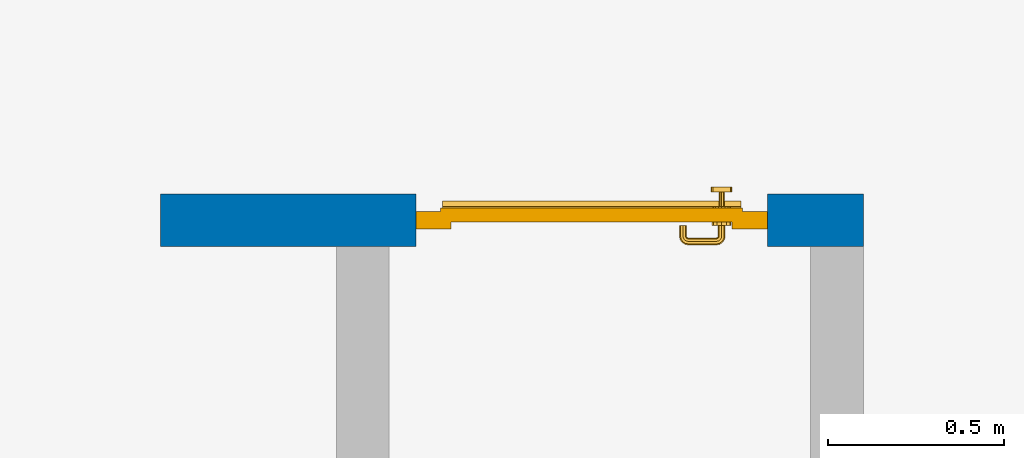
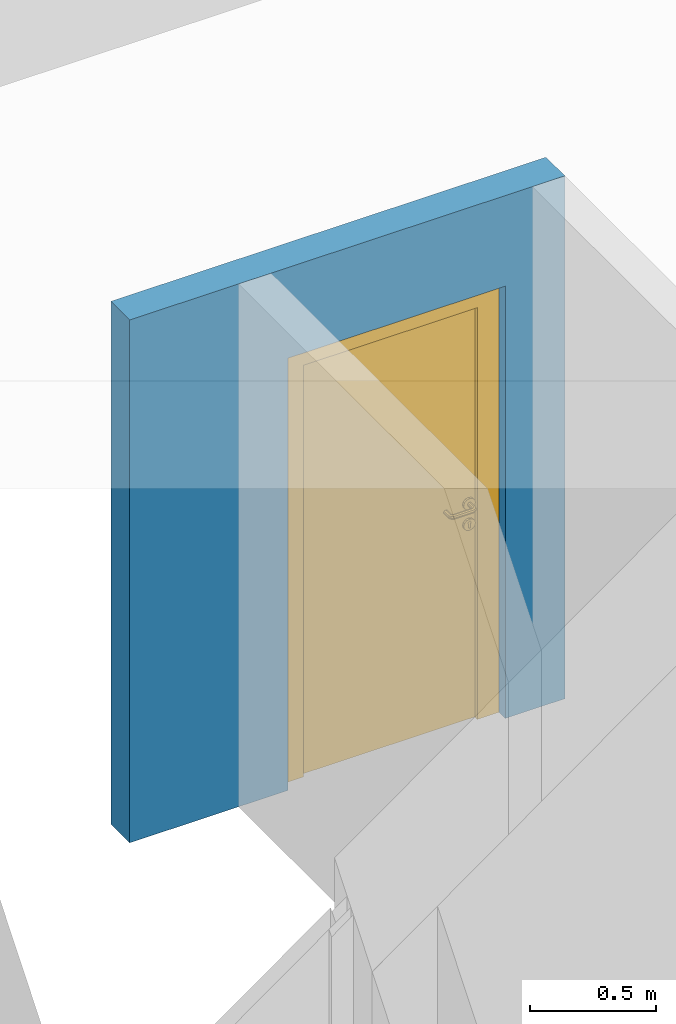
# One storey, part 20 of 48: 1 door, 1 wall, 1 opening.
"""IFC4 building model written with IfcOpenShell, lengths in metres."""

from ifc_helpers import new_model, entity, si_unit, converted_unit, derived_unit, direction, frame, origin_with_axes, place, context, subcontext, project, spatial, polygons, source, transform, mapped, material, type_object, element, fill, save


model = new_model("IFC4")

# Units and contexts
model_context = context("Model", 3, precision=1e-05, world=origin_with_axes(), true_north=direction((0.0, 1.0)))
body_context = subcontext(model_context, "Body", "Model", "MODEL_VIEW")
ifc_project = project(units=[si_unit("LENGTHUNIT", "METRE"), si_unit("AREAUNIT", "SQUARE_METRE"), si_unit("VOLUMEUNIT", "CUBIC_METRE"), converted_unit("PLANEANGLEUNIT", "DEGREE", entity("IfcPlaneAngleMeasure", 0.0174532925199), si_unit("PLANEANGLEUNIT", "RADIAN"), dimensions=[0, 0, 0, 0, 0, 0, 0]), converted_unit("TIMEUNIT", "Year", entity("IfcTimeMeasure", 31556926.0), si_unit("TIMEUNIT", "SECOND"), dimensions=[0, 0, 1, 0, 0, 0, 0]), si_unit("MASSUNIT", "GRAM", prefix="KILO"), si_unit("THERMODYNAMICTEMPERATUREUNIT", "DEGREE_CELSIUS"), si_unit("LUMINOUSINTENSITYUNIT", "LUMEN"), si_unit("ENERGYUNIT", "JOULE", prefix="MEGA"), derived_unit("THERMALCONDUCTANCEUNIT", [(si_unit("POWERUNIT", "WATT"), 1), (si_unit("LENGTHUNIT", "METRE"), -1), (si_unit("THERMODYNAMICTEMPERATUREUNIT", "KELVIN"), -1)]), derived_unit("SPECIFICHEATCAPACITYUNIT", [(si_unit("ENERGYUNIT", "JOULE"), 1), (si_unit("MASSUNIT", "GRAM", prefix="KILO"), -1), (si_unit("THERMODYNAMICTEMPERATUREUNIT", "KELVIN"), -1)]), derived_unit("MASSDENSITYUNIT", [(si_unit("MASSUNIT", "GRAM", prefix="KILO"), 1), (si_unit("VOLUMEUNIT", "CUBIC_METRE"), -1)])], contexts=[model_context])

# Site, building, storey
site_placement = place(None, origin_with_axes())
site = spatial("IfcSite", under=ifc_project, at=site_placement, CompositionType="ELEMENT")
building_placement = place(site_placement, origin_with_axes())
building = spatial("IfcBuilding", under=site, at=building_placement, CompositionType="ELEMENT")
storey_placement = place(building_placement, frame((0.0, 0.0, 3.4), z_axis=(0.0, 0.0, 1.0), x_axis=(1.0, 0.0, 0.0)))
storey = spatial("IfcBuildingStorey", under=building, at=storey_placement, Name="1. Geschoss", CompositionType="ELEMENT", Elevation=3.4)

# Wall, opening, door
ifc_material = material()
wall_type = type_object("IfcWallType", Name="150", PredefinedType="NOTDEFINED")
wall_placement = place(storey_placement, frame((4.6878006196, 3.97118776896, 0.0), z_axis=(0.0, 0.0, 1.0), x_axis=(-1.0, 0.0, 0.0)))
wall = element("IfcWall", 1, at=wall_placement, inside=storey, type_object=wall_type, material=ifc_material, Name="Wand-002", PredefinedType="NOTDEFINED", context=body_context, shape_type="Tessellation", body=[
    polygons([(0.12346205006, 0.05, 0.0), (0.12346205006, 0.05, 2.1), (0.12346205006, 0.0, 2.1), (0.12346205006, 0.0, 0.0), (0.12346205006, 0.15, 0.0), (0.12346205006, 0.15, 2.1), (1.12346205006, 0.05, 2.1), (1.12346205006, 0.0, 2.1), (-0.15, 0.0, 0.0), (1.12346205006, 0.0, 0.0), (1.85, 0.0, 0.0), (1.85, 0.0, 2.54), (-0.15, 0.0, 2.54), (-0.15, 0.15, 0.0), (-0.15, 0.15, 2.54), (1.85, 0.15, 2.54), (1.85, 0.15, 0.0), (1.12346205006, 0.15, 0.0), (1.12346205006, 0.15, 2.1), (1.12346205006, 0.05, 0.0)], [[[1, 2, 3, 4]], [[2, 1, 5, 6]], [[2, 7, 8, 3]], [[9, 4, 3, 8, 10, 11, 12, 13]], [[5, 1, 4, 9, 14]], [[6, 5, 14, 15, 16, 17, 18, 19]], [[7, 2, 6, 19]], [[7, 20, 10, 8]], [[20, 18, 17, 11, 10]], [[12, 11, 17, 16]], [[13, 12, 16, 15]], [[15, 14, 9, 13]], [[20, 7, 19, 18]]], closed=True),
])
opening_placement = place(wall_placement, frame((0.62346205006, 0.0, 0.0), z_axis=(0.0, 0.0, 1.0), x_axis=(1.0, 0.0, 0.0)))
opening = element("IfcOpeningElement", 2, at=opening_placement, cuts=wall, context=body_context, identifier="Reference", shape_type="Tessellation", body=[
    polygons([(0.5, 0.05, 0.0), (0.5, 0.05, 2.1), (0.5, -0.001, 2.1), (0.5, -0.001, 0.0), (0.5, 0.151, 0.0), (0.5, 0.151, 2.1), (-0.5, 0.05, 2.1), (-0.5, -0.001, 2.1), (-0.5, 0.151, 2.1), (-0.5, -0.001, 0.0), (-0.5, 0.05, 0.0), (-0.5, 0.151, 0.0)], [[[1, 2, 3, 4]], [[2, 1, 5, 6]], [[7, 8, 3, 2, 6, 9]], [[8, 10, 4, 3]], [[1, 4, 10, 11, 12, 5]], [[6, 5, 12, 9]], [[7, 11, 10, 8]], [[11, 7, 9, 12]]], closed=True),
])
door_type = type_object("IfcDoorType", Name="Eingang 01 1-Fl 26", OperationType="SINGLE_SWING_LEFT", PredefinedType="DOOR")
shared_shape = source(origin_with_axes(), body_context, "Body", "Tessellation", [
    polygons([(-0.5, -0.05, 0.0), (-0.5, -0.05, 2.1), (-0.5, -0.03, 2.1), (-0.5, -0.03, 0.0), (-0.4, -0.05, 0.0), (-0.4, -0.05, 2.0), (-0.1301, -0.05, 2.0), (-0.0001, -0.05, 2.0), (0.4, -0.05, 2.0), (0.4, -0.05, 0.0), (0.5, -0.05, 0.0), (0.5, -0.05, 2.1), (0.5, -0.03, 2.1), (0.5, -0.03, 0.0), (0.4, -0.03, 0.0), (0.4, -0.03, 2.0), (-0.0001, -0.03, 2.0), (-0.1301, -0.03, 2.0), (-0.4, -0.03, 2.0), (-0.4, -0.03, 0.0)], [[[1, 2, 3, 4]], [[1, 5, 6, 7, 8, 9, 10, 11, 12, 2]], [[2, 12, 13, 3]], [[4, 3, 13, 14, 15, 16, 17, 18, 19, 20]], [[5, 1, 4, 20]], [[6, 5, 20, 19]], [[7, 6, 19, 18]], [[8, 7, 18, 17]], [[9, 8, 17, 16]], [[10, 9, 16, 15]], [[11, 10, 15, 14]], [[12, 11, 14, 13]]], closed=True),
    polygons([(-0.5, -0.03, 0.0), (-0.5, -0.03, 2.1), (-0.5, 0.0, 2.1), (-0.5, 0.0, 0.0), (-0.43, -0.03, 0.0), (-0.43, -0.03, 2.03), (-0.1001, -0.03, 2.03), (-0.0301, -0.03, 2.03), (0.43, -0.03, 2.03), (0.43, -0.03, 0.0), (0.5, -0.03, 0.0), (0.5, -0.03, 2.1), (0.5, 0.0, 2.1), (0.5, 0.0, 0.0), (0.43, 0.0, 0.0), (0.43, 0.0, 2.03), (-0.0301, 0.0, 2.03), (-0.1001, 0.0, 2.03), (-0.43, 0.0, 2.03), (-0.43, 0.0, 0.0)], [[[1, 2, 3, 4]], [[1, 5, 6, 7, 8, 9, 10, 11, 12, 2]], [[2, 12, 13, 3]], [[4, 3, 13, 14, 15, 16, 17, 18, 19, 20]], [[5, 1, 4, 20]], [[6, 5, 20, 19]], [[7, 6, 19, 18]], [[8, 7, 18, 17]], [[9, 8, 17, 16]], [[10, 9, 16, 15]], [[11, 10, 15, 14]], [[12, 11, 14, 13]]], closed=True),
    polygons([(-0.43, 0.01, 0.0), (-0.43, 0.01, 2.03), (0.43, 0.01, 2.03), (0.43, 0.01, 0.0), (-0.43, -0.03, 0.0), (-0.43, -0.03, 2.03), (0.43, -0.03, 2.03), (0.43, -0.03, 0.0)], [[[1, 2, 3, 4]], [[1, 5, 6, 2]], [[2, 6, 7, 3]], [[3, 7, 8, 4]], [[4, 8, 5, 1]], [[8, 7, 6, 5]]], closed=True),
    polygons([(-0.425, 0.03, 0.0), (-0.425, 0.03, 0.05), (0.425, 0.03, 0.05), (0.425, 0.03, 0.0), (-0.425, 0.01, 0.0), (-0.425, 0.01, 0.07), (-0.425, 0.015, 0.07), (0.425, 0.015, 0.07), (0.425, 0.01, 0.07), (0.425, 0.01, 0.0)], [[[1, 2, 3, 4]], [[1, 5, 6, 7, 2]], [[2, 7, 8, 3]], [[4, 3, 8, 9, 10]], [[5, 1, 4, 10]], [[6, 5, 10, 9]], [[7, 6, 9, 8]]], closed=True),
    polygons([(0.3835, -0.04, 1.0733826859), (0.3835, -0.0399, 1.0733826859), (0.37, -0.0399, 1.077), (0.37, -0.04, 1.077), (0.393382685902, -0.04, 1.0635), (0.393382685902, -0.0399, 1.0635), (0.3835, -0.0301, 1.0733826859), (0.37, -0.0301, 1.077), (0.3565, -0.0399, 1.0733826859), (0.3565, -0.04, 1.0733826859), (0.346617314098, -0.04, 1.0635), (0.343, -0.04, 1.05), (0.346617314098, -0.04, 1.0365), (0.3565, -0.04, 1.0266173141), (0.37, -0.04, 1.023), (0.3835, -0.04, 1.0266173141), (0.393382685902, -0.04, 1.0365), (0.397, -0.04, 1.05), (0.397, -0.0399, 1.05), (0.393382685902, -0.0301, 1.0635), (0.3835, -0.03, 1.0733826859), (0.37, -0.03, 1.077), (0.3565, -0.0301, 1.0733826859), (0.346617314098, -0.0399, 1.0635), (0.343, -0.0399, 1.05), (0.346617314098, -0.0399, 1.0365), (0.3565, -0.0399, 1.0266173141), (0.37, -0.0399, 1.023), (0.3835, -0.0399, 1.0266173141), (0.393382685902, -0.0399, 1.0365), (0.397, -0.0301, 1.05), (0.393382685902, -0.03, 1.0635), (0.397, -0.03, 1.05), (0.393382685902, -0.03, 1.0365), (0.3835, -0.03, 1.0266173141), (0.37, -0.03, 1.023), (0.3565, -0.03, 1.0266173141), (0.346617314098, -0.03, 1.0365), (0.343, -0.03, 1.05), (0.346617314098, -0.03, 1.0635), (0.3565, -0.03, 1.0733826859), (0.346617314098, -0.0301, 1.0635), (0.343, -0.0301, 1.05), (0.346617314098, -0.0301, 1.0365), (0.3565, -0.0301, 1.0266173141), (0.37, -0.0301, 1.023), (0.3835, -0.0301, 1.0266173141), (0.393382685902, -0.0301, 1.0365)], [[[1, 2, 3, 4]], [[5, 6, 2, 1]], [[2, 7, 8, 3]], [[4, 3, 9, 10]], [[4, 10, 11, 12, 13, 14, 15, 16, 17, 18, 5, 1]], [[18, 19, 6, 5]], [[6, 20, 7, 2]], [[7, 21, 22, 8]], [[3, 8, 23, 9]], [[10, 9, 24, 11]], [[11, 24, 25, 12]], [[12, 25, 26, 13]], [[13, 26, 27, 14]], [[14, 27, 28, 15]], [[15, 28, 29, 16]], [[16, 29, 30, 17]], [[17, 30, 19, 18]], [[19, 31, 20, 6]], [[20, 32, 21, 7]], [[22, 21, 32, 33, 34, 35, 36, 37, 38, 39, 40, 41]], [[8, 22, 41, 23]], [[9, 23, 42, 24]], [[24, 42, 43, 25]], [[25, 43, 44, 26]], [[26, 44, 45, 27]], [[27, 45, 46, 28]], [[28, 46, 47, 29]], [[29, 47, 48, 30]], [[30, 48, 31, 19]], [[31, 33, 32, 20]], [[48, 34, 33, 31]], [[47, 35, 34, 48]], [[46, 36, 35, 47]], [[45, 37, 36, 46]], [[44, 38, 37, 45]], [[43, 39, 38, 44]], [[42, 40, 39, 43]], [[23, 41, 40, 42]]], closed=True),
    polygons([(0.362532169224, -0.04, 0.959692280177), (0.363279754556, -0.04, 0.961639806549), (0.35655, -0.04, 0.973296083362), (0.346703916638, -0.04, 0.96345), (0.365, -0.04, 0.952886751346), (0.365, -0.04, 0.9544), (0.362532169224, -0.039, 0.959692280177), (0.363279754556, -0.039, 0.961639806549), (0.364624817685, -0.039, 0.965143815798), (0.364624817685, -0.04, 0.965143815798), (0.37, -0.04, 0.967425445323), (0.37, -0.04, 0.9769), (0.346617314098, -0.04, 0.9635), (0.3565, -0.04, 0.973382685902), (0.365, -0.04, 0.95), (0.3431, -0.04, 0.95), (0.365, -0.04, 0.947113248654), (0.365, -0.04, 0.941339745962), (0.365, -0.04, 0.9375), (0.365, -0.039, 0.9375), (0.365, -0.039, 0.941339745962), (0.365, -0.039, 0.947113248654), (0.365, -0.039, 0.95), (0.365, -0.039, 0.952886751346), (0.365, -0.039, 0.9544), (0.347569942042, -0.039, 0.96295), (0.35705, -0.039, 0.972430057958), (0.37, -0.039, 0.9759), (0.37, -0.039, 0.967425445323), (0.375375182315, -0.04, 0.965143815798), (0.376720245444, -0.04, 0.961639806549), (0.38345, -0.04, 0.973296083362), (0.37, -0.04, 0.977), (0.343, -0.04, 0.95), (0.346617314098, -0.0399, 0.9635), (0.3565, -0.0399, 0.973382685902), (0.346703916638, -0.04, 0.93655), (0.35655, -0.04, 0.926703916638), (0.37, -0.04, 0.9231), (0.37, -0.04, 0.9325), (0.366464466094, -0.04, 0.933964466094), (0.366464466094, -0.039, 0.933964466094), (0.37, -0.039, 0.9241), (0.35705, -0.039, 0.927569942042), (0.37, -0.039, 0.9325), (0.347569942042, -0.039, 0.93705), (0.3441, -0.039, 0.95), (0.347483339502, -0.039, 0.963), (0.357, -0.039, 0.972516660498), (0.37, -0.039, 0.976), (0.375375182315, -0.039, 0.965143815798), (0.38295, -0.039, 0.972430057958), (0.376720245444, -0.039, 0.961639806549), (0.377467830776, -0.039, 0.959692280177), (0.377467830776, -0.04, 0.959692280177), (0.375, -0.04, 0.9544), (0.375, -0.04, 0.952886751346), (0.393296083362, -0.04, 0.96345), (0.3835, -0.04, 0.973382685902), (0.37, -0.0399, 0.977), (0.346617314098, -0.04, 0.9365), (0.343, -0.0399, 0.95), (0.346617314098, -0.0301, 0.9635), (0.3565, -0.0301, 0.973382685902), (0.3565, -0.04, 0.926617314098), (0.37, -0.04, 0.923), (0.38345, -0.04, 0.926703916638), (0.375, -0.04, 0.941339745962), (0.375, -0.04, 0.9375), (0.373535533906, -0.04, 0.933964466094), (0.37, -0.039, 0.924), (0.357, -0.039, 0.927483339502), (0.38295, -0.039, 0.927569942042), (0.373535533906, -0.039, 0.933964466094), (0.375, -0.039, 0.9375), (0.375, -0.039, 0.941339745962), (0.347483339502, -0.039, 0.937), (0.344, -0.039, 0.95), (0.347483339502, -0.0389, 0.963), (0.357, -0.0389, 0.972516660498), (0.37, -0.0389, 0.976), (0.383, -0.039, 0.972516660498), (0.392430057958, -0.039, 0.96295), (0.375, -0.039, 0.952886751346), (0.375, -0.039, 0.9544), (0.375, -0.039, 0.95), (0.375, -0.039, 0.947113248654), (0.375, -0.04, 0.947113248654), (0.375, -0.04, 0.95), (0.3969, -0.04, 0.95), (0.393382685902, -0.04, 0.9635), (0.3835, -0.0399, 0.973382685902), (0.37, -0.0301, 0.977), (0.346617314098, -0.0399, 0.9365), (0.343, -0.0301, 0.95), (0.346617314098, -0.03, 0.9635), (0.3565, -0.03, 0.973382685902), (0.3565, -0.0399, 0.926617314098), (0.3835, -0.04, 0.926617314098), (0.37, -0.0399, 0.923), (0.393296083362, -0.04, 0.93655), (0.383, -0.039, 0.927483339502), (0.37, -0.0389, 0.924), (0.357, -0.0389, 0.927483339502), (0.392430057958, -0.039, 0.93705), (0.347483339502, -0.0389, 0.937), (0.344, -0.0389, 0.95), (0.347483339502, -0.0301, 0.963), (0.357, -0.0301, 0.972516660498), (0.37, -0.0301, 0.976), (0.383, -0.0389, 0.972516660498), (0.392516660498, -0.039, 0.963), (0.3959, -0.039, 0.95), (0.397, -0.04, 0.95), (0.393382685902, -0.0399, 0.9635), (0.3835, -0.0301, 0.973382685902), (0.37, -0.03, 0.977), (0.346617314098, -0.0301, 0.9365), (0.343, -0.03, 0.95), (0.346703916638, -0.03, 0.96345), (0.35655, -0.03, 0.973296083362), (0.3565, -0.0301, 0.926617314098), (0.393382685902, -0.04, 0.9365), (0.3835, -0.0399, 0.926617314098), (0.37, -0.0301, 0.923), (0.392516660498, -0.039, 0.937), (0.383, -0.0389, 0.927483339502), (0.37, -0.0301, 0.924), (0.357, -0.0301, 0.927483339502), (0.347483339502, -0.0301, 0.937), (0.344, -0.0301, 0.95), (0.347483339502, -0.03, 0.963), (0.357, -0.03, 0.972516660498), (0.37, -0.03, 0.976), (0.383, -0.0301, 0.972516660498), (0.392516660498, -0.0389, 0.963), (0.396, -0.039, 0.95), (0.397, -0.0399, 0.95), (0.393382685902, -0.0301, 0.9635), (0.3835, -0.03, 0.973382685902), (0.37, -0.03, 0.9769), (0.346617314098, -0.03, 0.9365), (0.3431, -0.03, 0.95), (0.347396736961, -0.03, 0.96305), (0.35695, -0.03, 0.972603263039), (0.3565, -0.03, 0.926617314098), (0.393382685902, -0.0399, 0.9365), (0.3835, -0.0301, 0.926617314098), (0.37, -0.03, 0.923), (0.392516660498, -0.0389, 0.937), (0.383, -0.0301, 0.927483339502), (0.37, -0.03, 0.924), (0.357, -0.03, 0.927483339502), (0.347483339502, -0.03, 0.937), (0.344, -0.03, 0.95), (0.37, -0.03, 0.9761), (0.383, -0.03, 0.972516660498), (0.392516660498, -0.0301, 0.963), (0.396, -0.0389, 0.95), (0.397, -0.0301, 0.95), (0.393382685902, -0.03, 0.9635), (0.38345, -0.03, 0.973296083362), (0.346703916638, -0.03, 0.93655), (0.3439, -0.03, 0.95), (0.35655, -0.03, 0.926703916638), (0.393382685902, -0.0301, 0.9365), (0.3835, -0.03, 0.926617314098), (0.37, -0.03, 0.9231), (0.392516660498, -0.0301, 0.937), (0.383, -0.03, 0.927483339502), (0.37, -0.03, 0.9239), (0.35695, -0.03, 0.927396736961), (0.347396736961, -0.03, 0.93695), (0.38305, -0.03, 0.972603263039), (0.392516660498, -0.03, 0.963), (0.396, -0.0301, 0.95), (0.397, -0.03, 0.95), (0.393296083362, -0.03, 0.96345), (0.393382685902, -0.03, 0.9365), (0.38345, -0.03, 0.926703916638), (0.392516660498, -0.03, 0.937), (0.38305, -0.03, 0.927396736961), (0.392603263039, -0.03, 0.96305), (0.396, -0.03, 0.95), (0.3969, -0.03, 0.95), (0.393296083362, -0.03, 0.93655), (0.392603263039, -0.03, 0.93695), (0.3961, -0.03, 0.95)], [[[1, 2, 3, 4, 5, 6]], [[1, 7, 8, 9, 10, 2]], [[10, 11, 12, 3, 2]], [[13, 4, 3, 14]], [[15, 5, 4, 16]], [[6, 5, 15, 17, 18, 19, 20, 21, 22, 23, 24, 25]], [[6, 25, 7, 1]], [[7, 25, 24, 26, 27, 8]], [[9, 8, 27, 28, 29]], [[10, 9, 29, 11]], [[30, 31, 32, 12, 11]], [[14, 3, 12, 33]], [[34, 16, 4, 13]], [[35, 13, 14, 36]], [[17, 15, 16, 37]], [[18, 17, 37, 38]], [[38, 39, 40, 41, 19, 18]], [[19, 41, 42, 20]], [[43, 44, 21, 20, 42, 45]], [[22, 21, 44, 46]], [[23, 22, 46, 47]], [[24, 23, 47, 26]], [[26, 48, 49, 27]], [[27, 49, 50, 28]], [[51, 29, 28, 52, 53]], [[11, 29, 51, 30]], [[30, 51, 53, 54, 55, 31]], [[55, 56, 57, 58, 32, 31]], [[33, 12, 32, 59]], [[36, 14, 33, 60]], [[61, 37, 16, 34]], [[62, 34, 13, 35]], [[63, 35, 36, 64]], [[65, 38, 37, 61]], [[66, 39, 38, 65]], [[39, 67, 68, 69, 70, 40]], [[41, 40, 45, 42]], [[43, 71, 72, 44]], [[73, 43, 45, 74, 75, 76]], [[44, 72, 77, 46]], [[46, 77, 78, 47]], [[47, 78, 48, 26]], [[48, 79, 80, 49]], [[49, 80, 81, 50]], [[28, 50, 82, 52]], [[54, 53, 52, 83, 84, 85]], [[55, 54, 85, 56]], [[85, 84, 86, 87, 76, 75, 69, 68, 88, 89, 57, 56]], [[57, 89, 90, 58]], [[59, 32, 58, 91]], [[60, 33, 59, 92]], [[64, 36, 60, 93]], [[94, 61, 34, 62]], [[95, 62, 35, 63]], [[96, 63, 64, 97]], [[98, 65, 61, 94]], [[99, 67, 39, 66]], [[100, 66, 65, 98]], [[88, 68, 67, 101]], [[70, 69, 75, 74]], [[40, 70, 74, 45]], [[73, 102, 71, 43]], [[71, 103, 104, 72]], [[76, 87, 105, 73]], [[72, 104, 106, 77]], [[77, 106, 107, 78]], [[78, 107, 79, 48]], [[79, 108, 109, 80]], [[80, 109, 110, 81]], [[50, 81, 111, 82]], [[52, 82, 112, 83]], [[86, 84, 83, 113]], [[87, 86, 113, 105]], [[89, 88, 101, 90]], [[91, 58, 90, 114]], [[92, 59, 91, 115]], [[93, 60, 92, 116]], [[97, 64, 93, 117]], [[118, 94, 62, 95]], [[119, 95, 63, 96]], [[120, 96, 97, 121]], [[122, 98, 94, 118]], [[123, 101, 67, 99]], [[124, 99, 66, 100]], [[125, 100, 98, 122]], [[105, 126, 102, 73]], [[102, 127, 103, 71]], [[103, 128, 129, 104]], [[104, 129, 130, 106]], [[106, 130, 131, 107]], [[107, 131, 108, 79]], [[108, 132, 133, 109]], [[109, 133, 134, 110]], [[81, 110, 135, 111]], [[82, 111, 136, 112]], [[83, 112, 137, 113]], [[113, 137, 126, 105]], [[114, 90, 101, 123]], [[115, 91, 114, 138]], [[116, 92, 115, 139]], [[117, 93, 116, 140]], [[121, 97, 117, 141]], [[142, 118, 95, 119]], [[143, 119, 96, 120]], [[144, 120, 121, 145]], [[146, 122, 118, 142]], [[147, 123, 99, 124]], [[148, 124, 100, 125]], [[149, 125, 122, 146]], [[126, 150, 127, 102]], [[127, 151, 128, 103]], [[128, 152, 153, 129]], [[129, 153, 154, 130]], [[130, 154, 155, 131]], [[131, 155, 132, 108]], [[132, 144, 145, 133]], [[133, 145, 156, 134]], [[110, 134, 157, 135]], [[111, 135, 158, 136]], [[112, 136, 159, 137]], [[137, 159, 150, 126]], [[138, 114, 123, 147]], [[139, 115, 138, 160]], [[140, 116, 139, 161]], [[141, 117, 140, 162]], [[145, 121, 141, 156]], [[163, 142, 119, 143]], [[164, 143, 120, 144]], [[165, 146, 142, 163]], [[166, 147, 124, 148]], [[167, 148, 125, 149]], [[168, 149, 146, 165]], [[150, 169, 151, 127]], [[151, 170, 152, 128]], [[152, 171, 172, 153]], [[153, 172, 173, 154]], [[154, 173, 164, 155]], [[155, 164, 144, 132]], [[134, 156, 174, 157]], [[135, 157, 175, 158]], [[136, 158, 176, 159]], [[159, 176, 169, 150]], [[160, 138, 147, 166]], [[161, 139, 160, 177]], [[162, 140, 161, 178]], [[156, 141, 162, 174]], [[173, 163, 143, 164]], [[172, 165, 163, 173]], [[179, 166, 148, 167]], [[180, 167, 149, 168]], [[171, 168, 165, 172]], [[169, 181, 170, 151]], [[170, 182, 171, 152]], [[157, 174, 183, 175]], [[158, 175, 184, 176]], [[176, 184, 181, 169]], [[177, 160, 166, 179]], [[178, 161, 177, 185]], [[174, 162, 178, 183]], [[186, 179, 167, 180]], [[182, 180, 168, 171]], [[181, 187, 182, 170]], [[175, 183, 188, 184]], [[184, 188, 187, 181]], [[185, 177, 179, 186]], [[183, 178, 185, 188]], [[187, 186, 180, 182]], [[188, 185, 186, 187]]], closed=True),
    polygons([(0.38, -0.04, 1.05), (0.38, -0.0709849140336, 1.05), (0.377071067812, -0.070696439392, 1.04292893219), (0.377071067812, -0.04, 1.04292893219), (0.377071067812, -0.04, 1.05707106781), (0.377071067812, -0.070696439392, 1.05707106781), (0.378277987014, -0.0796420579258, 1.05), (0.375518993221, -0.0784992452783, 1.04292893219), (0.37, -0.07, 1.04), (0.37, -0.04, 1.04), (0.37, -0.04, 1.06), (0.37, -0.07, 1.06), (0.375518993221, -0.0784992452783, 1.05707106781), (0.372816199938, -0.0878161999379, 1.05), (0.370704557509, -0.0857045575088, 1.04292893219), (0.368858192988, -0.0757402514855, 1.04), (0.362928932188, -0.069303560608, 1.04292893219), (0.362928932188, -0.04, 1.04292893219), (0.362928932188, -0.04, 1.05707106781), (0.362928932188, -0.069303560608, 1.05707106781), (0.368858192988, -0.0757402514855, 1.06), (0.370704557509, -0.0857045575088, 1.05707106781), (0.364642057926, -0.0932779870137, 1.05), (0.363499245278, -0.0905189932208, 1.04292893219), (0.365606601718, -0.0806066017178, 1.04), (0.362197392755, -0.0729812576926, 1.04292893219), (0.36, -0.0690150859664, 1.05), (0.36, -0.04, 1.05), (0.362197392755, -0.0729812576926, 1.05707106781), (0.365606601718, -0.0806066017178, 1.06), (0.363499245278, -0.0905189932208, 1.05707106781), (0.355984914034, -0.095, 1.05), (0.355696439392, -0.0920710678119, 1.04292893219), (0.360740251485, -0.0838581929877, 1.04), (0.360508645927, -0.0755086459268, 1.04292893219), (0.359438398962, -0.0718384450452, 1.05), (0.360508645927, -0.0755086459268, 1.05707106781), (0.360740251485, -0.0838581929877, 1.06), (0.355696439392, -0.0920710678119, 1.05707106781), (0.274015085966, -0.095, 1.05), (0.274303560608, -0.0920710678119, 1.04292893219), (0.355, -0.085, 1.04), (0.357981257693, -0.0771973927545, 1.04292893219), (0.358397003498, -0.0733970034977, 1.05), (0.357981257693, -0.0771973927545, 1.05707106781), (0.355, -0.085, 1.06), (0.274303560608, -0.0920710678119, 1.05707106781), (0.265357942074, -0.0932779870137, 1.05), (0.266500754722, -0.0905189932208, 1.04292893219), (0.275, -0.085, 1.04), (0.354303560608, -0.0779289321881, 1.04292893219), (0.356838445045, -0.0744383989617, 1.05), (0.354303560608, -0.0779289321881, 1.05707106781), (0.275, -0.085, 1.06), (0.266500754722, -0.0905189932208, 1.05707106781), (0.257183800062, -0.0878161999379, 1.05), (0.259295442491, -0.0857045575088, 1.04292893219), (0.269259748515, -0.0838581929877, 1.04), (0.275696439392, -0.0779289321881, 1.04292893219), (0.354015085966, -0.075, 1.05), (0.275696439392, -0.0779289321881, 1.05707106781), (0.269259748515, -0.0838581929877, 1.06), (0.259295442491, -0.0857045575088, 1.05707106781), (0.251722012986, -0.0796420579258, 1.05), (0.254481006779, -0.0784992452783, 1.04292893219), (0.264393398282, -0.0806066017178, 1.04), (0.272018742307, -0.0771973927545, 1.04292893219), (0.275984914034, -0.075, 1.05), (0.272018742307, -0.0771973927545, 1.05707106781), (0.264393398282, -0.0806066017178, 1.06), (0.254481006779, -0.0784992452783, 1.05707106781), (0.25, -0.0709849140336, 1.05), (0.252928932188, -0.070696439392, 1.04292893219), (0.261141807012, -0.0757402514855, 1.04), (0.269491354073, -0.0755086459268, 1.04292893219), (0.273161554955, -0.0744383989617, 1.05), (0.269491354073, -0.0755086459268, 1.05707106781), (0.261141807012, -0.0757402514855, 1.06), (0.252928932188, -0.070696439392, 1.05707106781), (0.25, -0.04, 1.05), (0.252928932188, -0.04, 1.04292893219), (0.26, -0.07, 1.04), (0.267802607245, -0.0729812576926, 1.04292893219), (0.271602996502, -0.0733970034977, 1.05), (0.267802607245, -0.0729812576926, 1.05707106781), (0.26, -0.07, 1.06), (0.252928932188, -0.04, 1.05707106781), (0.26, -0.04, 1.06), (0.267071067812, -0.04, 1.05707106781), (0.27, -0.04, 1.05), (0.267071067812, -0.04, 1.04292893219), (0.26, -0.04, 1.04), (0.267071067812, -0.069303560608, 1.04292893219), (0.270561601038, -0.0718384450452, 1.05), (0.267071067812, -0.069303560608, 1.05707106781), (0.27, -0.0690150859664, 1.05)], [[[1, 2, 3, 4]], [[5, 6, 2, 1]], [[2, 7, 8, 3]], [[4, 3, 9, 10]], [[11, 12, 6, 5]], [[6, 13, 7, 2]], [[7, 14, 15, 8]], [[3, 8, 16, 9]], [[10, 9, 17, 18]], [[19, 20, 12, 11]], [[12, 21, 13, 6]], [[13, 22, 14, 7]], [[14, 23, 24, 15]], [[8, 15, 25, 16]], [[9, 16, 26, 17]], [[18, 17, 27, 28]], [[28, 27, 20, 19]], [[20, 29, 21, 12]], [[21, 30, 22, 13]], [[22, 31, 23, 14]], [[23, 32, 33, 24]], [[15, 24, 34, 25]], [[16, 25, 35, 26]], [[17, 26, 36, 27]], [[27, 36, 29, 20]], [[29, 37, 30, 21]], [[30, 38, 31, 22]], [[31, 39, 32, 23]], [[32, 40, 41, 33]], [[24, 33, 42, 34]], [[25, 34, 43, 35]], [[26, 35, 44, 36]], [[36, 44, 37, 29]], [[37, 45, 38, 30]], [[38, 46, 39, 31]], [[39, 47, 40, 32]], [[40, 48, 49, 41]], [[33, 41, 50, 42]], [[34, 42, 51, 43]], [[35, 43, 52, 44]], [[44, 52, 45, 37]], [[45, 53, 46, 38]], [[46, 54, 47, 39]], [[47, 55, 48, 40]], [[48, 56, 57, 49]], [[41, 49, 58, 50]], [[42, 50, 59, 51]], [[43, 51, 60, 52]], [[52, 60, 53, 45]], [[53, 61, 54, 46]], [[54, 62, 55, 47]], [[55, 63, 56, 48]], [[56, 64, 65, 57]], [[49, 57, 66, 58]], [[50, 58, 67, 59]], [[51, 59, 68, 60]], [[60, 68, 61, 53]], [[61, 69, 62, 54]], [[62, 70, 63, 55]], [[63, 71, 64, 56]], [[64, 72, 73, 65]], [[57, 65, 74, 66]], [[58, 66, 75, 67]], [[59, 67, 76, 68]], [[68, 76, 69, 61]], [[69, 77, 70, 62]], [[70, 78, 71, 63]], [[71, 79, 72, 64]], [[72, 80, 81, 73]], [[65, 73, 82, 74]], [[66, 74, 83, 75]], [[67, 75, 84, 76]], [[76, 84, 77, 69]], [[77, 85, 78, 70]], [[78, 86, 79, 71]], [[79, 87, 80, 72]], [[80, 87, 88, 89, 90, 91, 92, 81]], [[73, 81, 92, 82]], [[74, 82, 93, 83]], [[75, 83, 94, 84]], [[84, 94, 85, 77]], [[85, 95, 86, 78]], [[86, 88, 87, 79]], [[95, 89, 88, 86]], [[96, 90, 89, 95]], [[93, 91, 90, 96]], [[82, 92, 91, 93]], [[83, 93, 96, 94]], [[94, 96, 95, 85]]], closed=False),
    polygons([(0.364696699141, 0.015, 1.04469669914), (0.37, 0.015, 1.0425), (0.375303300859, 0.015, 1.04469669914), (0.3775, 0.015, 1.05), (0.375303300859, 0.015, 1.05530330086), (0.37, 0.015, 1.0575), (0.364696699141, 0.015, 1.05530330086), (0.3625, 0.015, 1.05), (0.364696699141, 0.055, 1.04469669914), (0.37, 0.055, 1.0425), (0.375303300859, 0.055, 1.04469669914), (0.3775, 0.055, 1.05), (0.375303300859, 0.055, 1.05530330086), (0.37, 0.055, 1.0575), (0.364696699141, 0.055, 1.05530330086), (0.3625, 0.055, 1.05)], [[[1, 2, 3, 4, 5, 6, 7, 8]], [[2, 1, 9, 10]], [[3, 2, 10, 11]], [[4, 3, 11, 12]], [[5, 4, 12, 13]], [[6, 5, 13, 14]], [[7, 6, 14, 15]], [[8, 7, 15, 16]], [[1, 8, 16, 9]], [[9, 16, 15, 14, 13, 12, 11, 10]]], closed=True),
    polygons([(0.395, 0.01, 0.975), (0.393096988313, 0.01, 0.965432914191), (0.393096988313, 0.015, 0.965432914191), (0.395, 0.015, 0.975), (0.395, 0.01, 1.1), (0.393096988313, 0.01, 1.10956708581), (0.38767766953, 0.01, 1.11767766953), (0.379567085809, 0.01, 1.12309698831), (0.37, 0.01, 1.125), (0.360432914191, 0.01, 1.12309698831), (0.35232233047, 0.01, 1.11767766953), (0.346903011687, 0.01, 1.10956708581), (0.345, 0.01, 1.1), (0.345, 0.01, 0.975), (0.346903011687, 0.01, 0.965432914191), (0.35232233047, 0.01, 0.95732233047), (0.360432914191, 0.01, 0.951903011687), (0.37, 0.01, 0.95), (0.379567085809, 0.01, 0.951903011687), (0.38767766953, 0.01, 0.95732233047), (0.38767766953, 0.015, 0.95732233047), (0.379567085809, 0.015, 0.951903011687), (0.37, 0.015, 0.95), (0.360432914191, 0.015, 0.951903011687), (0.35232233047, 0.015, 0.95732233047), (0.346903011687, 0.015, 0.965432914191), (0.345, 0.015, 0.975), (0.345, 0.015, 1.1), (0.346903011687, 0.015, 1.10956708581), (0.35232233047, 0.015, 1.11767766953), (0.360432914191, 0.015, 1.12309698831), (0.37, 0.015, 1.125), (0.379567085809, 0.015, 1.12309698831), (0.38767766953, 0.015, 1.11767766953), (0.393096988313, 0.015, 1.10956708581), (0.395, 0.015, 1.1)], [[[1, 2, 3, 4]], [[1, 5, 6, 7, 8, 9, 10, 11, 12, 13, 14, 15, 16, 17, 18, 19, 20, 2]], [[2, 20, 21, 3]], [[4, 3, 21, 22, 23, 24, 25, 26, 27, 28, 29, 30, 31, 32, 33, 34, 35, 36]], [[5, 1, 4, 36]], [[6, 5, 36, 35]], [[7, 6, 35, 34]], [[8, 7, 34, 33]], [[9, 8, 33, 32]], [[10, 9, 32, 31]], [[11, 10, 31, 30]], [[12, 11, 30, 29]], [[13, 12, 29, 28]], [[14, 13, 28, 27]], [[15, 14, 27, 26]], [[16, 15, 26, 25]], [[17, 16, 25, 24]], [[18, 17, 24, 23]], [[19, 18, 23, 22]], [[20, 19, 22, 21]]], closed=True),
    polygons([(0.39, 0.055, 1.08), (0.395, 0.055, 1.07866025404), (0.395, 0.07, 1.07866025404), (0.39, 0.07, 1.08), (0.35, 0.055, 1.08), (0.345, 0.055, 1.07866025404), (0.341339745962, 0.055, 1.075), (0.34, 0.055, 1.07), (0.34, 0.055, 1.03), (0.341339745962, 0.055, 1.025), (0.345, 0.055, 1.02133974596), (0.35, 0.055, 1.02), (0.39, 0.055, 1.02), (0.395, 0.055, 1.02133974596), (0.398660254038, 0.055, 1.025), (0.4, 0.055, 1.03), (0.4, 0.055, 1.07), (0.398660254038, 0.055, 1.075), (0.398660254038, 0.07, 1.075), (0.4, 0.07, 1.07), (0.4, 0.07, 1.03), (0.398660254038, 0.07, 1.025), (0.395, 0.07, 1.02133974596), (0.39, 0.07, 1.02), (0.35, 0.07, 1.02), (0.345, 0.07, 1.02133974596), (0.341339745962, 0.07, 1.025), (0.34, 0.07, 1.03), (0.34, 0.07, 1.07), (0.341339745962, 0.07, 1.075), (0.345, 0.07, 1.07866025404), (0.35, 0.07, 1.08)], [[[1, 2, 3, 4]], [[1, 5, 6, 7, 8, 9, 10, 11, 12, 13, 14, 15, 16, 17, 18, 2]], [[2, 18, 19, 3]], [[4, 3, 19, 20, 21, 22, 23, 24, 25, 26, 27, 28, 29, 30, 31, 32]], [[5, 1, 4, 32]], [[6, 5, 32, 31]], [[7, 6, 31, 30]], [[8, 7, 30, 29]], [[9, 8, 29, 28]], [[10, 9, 28, 27]], [[11, 10, 27, 26]], [[12, 11, 26, 25]], [[13, 12, 25, 24]], [[14, 13, 24, 23]], [[15, 14, 23, 22]], [[16, 15, 22, 21]], [[17, 16, 21, 20]], [[18, 17, 20, 19]]], closed=True),
])
door_placement = place(opening_placement, frame((0.4, 0.0, 0.0), z_axis=(0.0, 0.0, 1.0), x_axis=(-1.0, 0.0, 0.0)))
door = element("IfcDoor", 3, at=door_placement, inside=storey, type_object=door_type, OverallHeight=2.1, OverallWidth=1.0, PredefinedType="DOOR", context=body_context, shape_type="MappedRepresentation", body=[
    mapped(shared_shape, transform((0.4, -0.05, 0.0))),
])
fill(opening, door)

save(model, "model.ifc")
